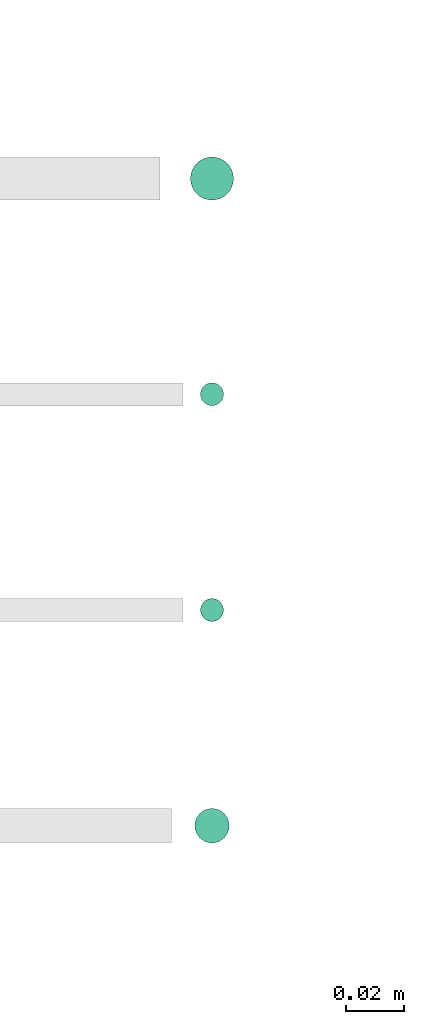
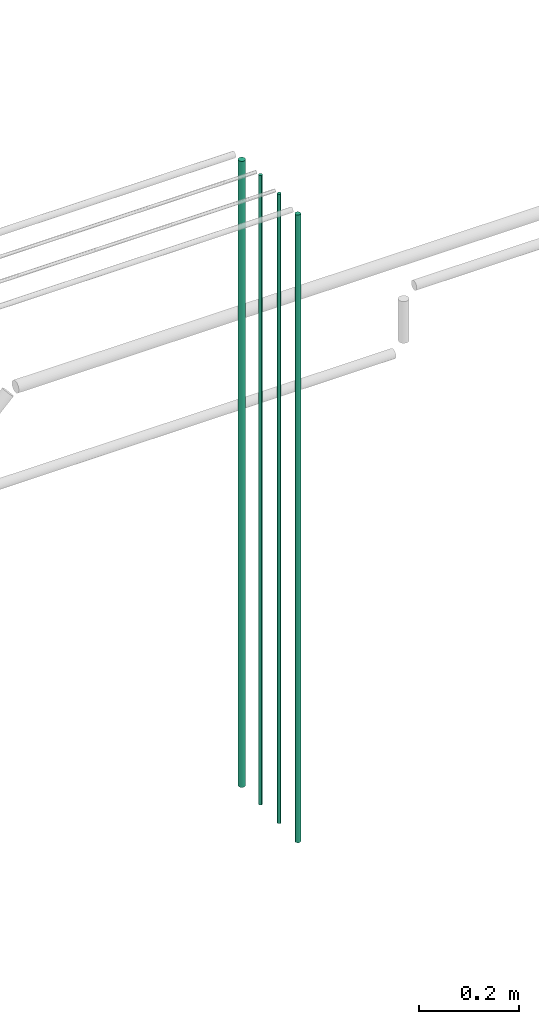
# One storey, part 9 of 331: 4 flow segments.
"""IFC2X3 building model written with IfcOpenShell, lengths in millimetres."""

from ifc_helpers import new_model, entity, si_unit, converted_unit, derived_unit, direction, frame, origin, origin_2d_with_axis, place, context, subcontext, project, spatial, circle, extrude, type_object, element, save


model = new_model("IFC2X3")

# Units and contexts
model_context = context("Model", 3, precision=0.01, world=origin(), true_north=direction((6.12303176911189e-17, 1.0)))
body_context = subcontext(model_context, "Body", "Model", "MODEL_VIEW")
ifc_project = project(units=[si_unit("LENGTHUNIT", "METRE", prefix="MILLI"), si_unit("AREAUNIT", "SQUARE_METRE"), si_unit("VOLUMEUNIT", "CUBIC_METRE"), converted_unit("PLANEANGLEUNIT", "DEGREE", entity("IfcRatioMeasure", 0.0174532925199433), si_unit("PLANEANGLEUNIT", "RADIAN"), dimensions=[0, 0, 0, 0, 0, 0, 0]), si_unit("MASSUNIT", "GRAM", prefix="KILO"), derived_unit("MASSDENSITYUNIT", [(si_unit("MASSUNIT", "GRAM", prefix="KILO"), 1), (si_unit("LENGTHUNIT", "METRE"), -3)]), derived_unit("MOMENTOFINERTIAUNIT", [(si_unit("LENGTHUNIT", "METRE"), 4)]), si_unit("TIMEUNIT", "SECOND"), si_unit("FREQUENCYUNIT", "HERTZ"), si_unit("THERMODYNAMICTEMPERATUREUNIT", "DEGREE_CELSIUS"), derived_unit("THERMALTRANSMITTANCEUNIT", [(si_unit("MASSUNIT", "GRAM", prefix="KILO"), 1), (si_unit("THERMODYNAMICTEMPERATUREUNIT", "KELVIN"), -1), (si_unit("TIMEUNIT", "SECOND"), -3)]), derived_unit("VOLUMETRICFLOWRATEUNIT", [(si_unit("LENGTHUNIT", "METRE"), 3), (si_unit("TIMEUNIT", "SECOND"), -1)]), derived_unit("MASSFLOWRATEUNIT", [(si_unit("MASSUNIT", "GRAM", prefix="KILO"), 1), (si_unit("TIMEUNIT", "SECOND"), -1)]), derived_unit("ROTATIONALFREQUENCYUNIT", [(si_unit("TIMEUNIT", "SECOND"), -1)]), si_unit("ELECTRICCURRENTUNIT", "AMPERE"), si_unit("ELECTRICVOLTAGEUNIT", "VOLT"), si_unit("POWERUNIT", "WATT"), si_unit("FORCEUNIT", "NEWTON", prefix="KILO"), si_unit("ILLUMINANCEUNIT", "LUX"), si_unit("LUMINOUSFLUXUNIT", "LUMEN"), si_unit("LUMINOUSINTENSITYUNIT", "CANDELA"), derived_unit("USERDEFINED", [(si_unit("MASSUNIT", "GRAM", prefix="KILO"), -1), (si_unit("LENGTHUNIT", "METRE"), -2), (si_unit("TIMEUNIT", "SECOND"), 3), (si_unit("LUMINOUSFLUXUNIT", "LUMEN"), 1)]), derived_unit("LINEARVELOCITYUNIT", [(si_unit("LENGTHUNIT", "METRE"), 1), (si_unit("TIMEUNIT", "SECOND"), -1)]), si_unit("PRESSUREUNIT", "PASCAL"), derived_unit("USERDEFINED", [(si_unit("LENGTHUNIT", "METRE"), -2), (si_unit("MASSUNIT", "GRAM", prefix="KILO"), 1), (si_unit("TIMEUNIT", "SECOND"), -2)]), derived_unit("LINEARFORCEUNIT", [(si_unit("MASSUNIT", "GRAM", prefix="KILO"), 1), (si_unit("LENGTHUNIT", "METRE"), 1), (si_unit("TIMEUNIT", "SECOND"), -2), (si_unit("LENGTHUNIT", "METRE"), -1)]), derived_unit("PLANARFORCEUNIT", [(si_unit("MASSUNIT", "GRAM", prefix="KILO"), 1), (si_unit("LENGTHUNIT", "METRE"), 1), (si_unit("TIMEUNIT", "SECOND"), -2), (si_unit("LENGTHUNIT", "METRE"), -2)])], contexts=[model_context])

# Site, building, storey
site_placement = place(None, frame((0.0, -0.00077364408347762, 0.0)))
site = spatial("IfcSite", under=ifc_project, at=site_placement, CompositionType="ELEMENT")
building_placement = place(site_placement, origin())
building = spatial("IfcBuilding", under=site, at=building_placement, CompositionType="ELEMENT")
storey_placement = place(building_placement, origin())
storey = spatial("IfcBuildingStorey", under=building, at=storey_placement, CompositionType="ELEMENT", Elevation=0.0)

# Flow segments
pipe_segment_type = type_object("IfcPipeSegmentType", PredefinedType="NOTDEFINED")
flow_segment_1_placement = place(storey_placement, frame((33006.3314195064, 3135.27987825006, 5700.0)))
element("IfcFlowSegment", 1, at=flow_segment_1_placement, inside=storey, type_object=pipe_segment_type, context=body_context, shape_type="SweptSolid", body=[
    extrude(circle(Radius=7.5, at=origin_2d_with_axis()), frame((9.09527223591419, 9.09527223591582, 0.0)), (0.0, 0.0, 1.0), 1532.0),
])
for number, where in (
    (2, (33009.8314195064, 3063.77987825006, 5700.0)),
    (3, (33009.8314195063, 2988.77987825006, 5700.0)),
):
    element("IfcFlowSegment", number, at=place(storey_placement, frame(where)), inside=storey, type_object=pipe_segment_type, context=body_context, shape_type="SweptSolid", body=[
        extrude(circle(Radius=4.0, at=origin_2d_with_axis()), frame((5.59527223591499, 5.59527223591607, 0.0)), (0.0, 0.0, 1.0), 1540.0),
    ])
flow_segment_2_placement = place(storey_placement, frame((33007.8314195063, 2911.77987825006, 5700.0)))
element("IfcFlowSegment", 4, at=flow_segment_2_placement, inside=storey, type_object=pipe_segment_type, context=body_context, shape_type="SweptSolid", body=[
    extrude(circle(Radius=6.0, at=origin_2d_with_axis()), frame((7.59527223591454, 7.59527223591616, 0.0)), (0.0, 0.0, 1.0), 1536.0),
])

save(model, "model.ifc")
